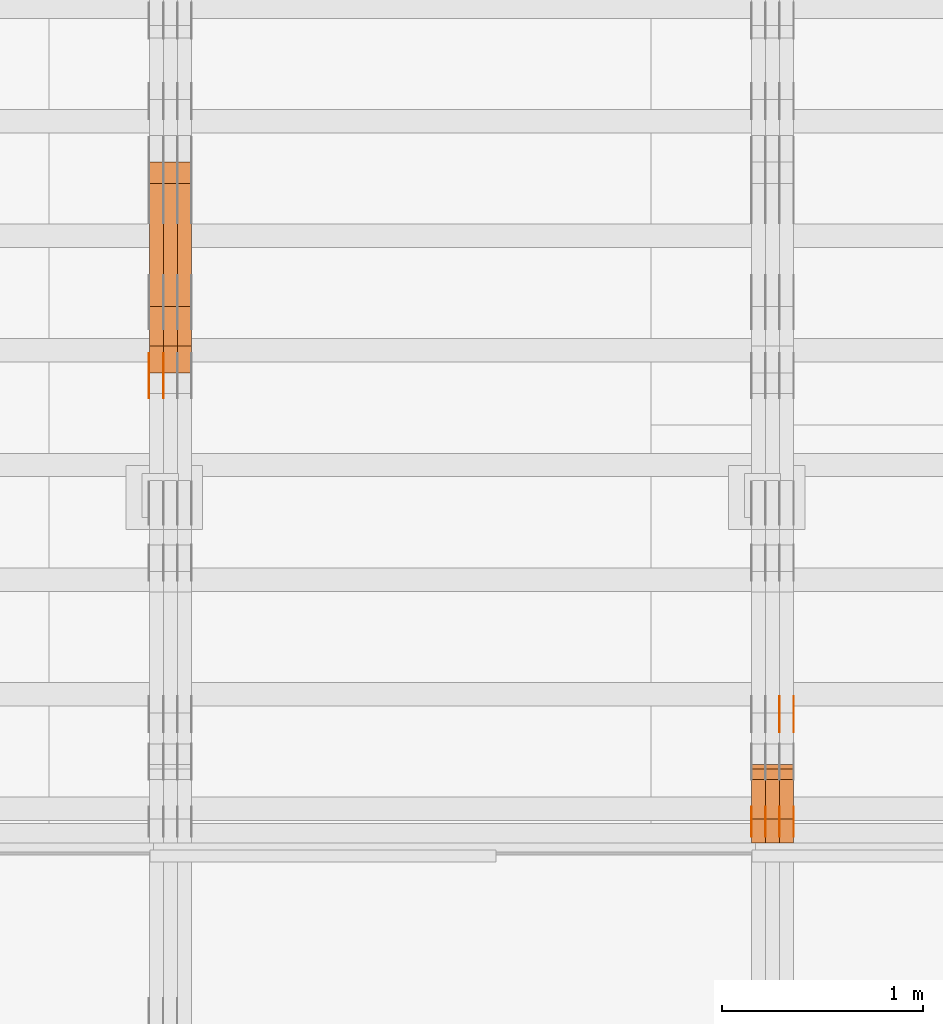
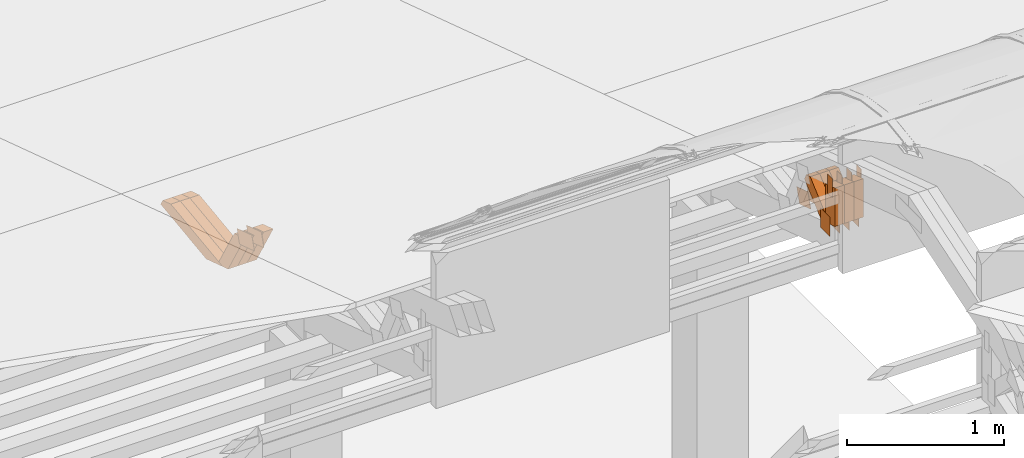
# One storey, part 302 of 385: 30 proxies.
"""IFC2X3 building model written with IfcOpenShell, lengths in millimetres."""

from ifc_helpers import new_model, entity, si_unit, converted_unit, derived_unit, direction, frame, origin, origin_2d_with_axis, place, context, subcontext, project, spatial, polyline, rectangle, outline, extrude, source, transform, mapped, material, type_object, type_shapes, element, save


model = new_model("IFC2X3")

# Units and contexts
model_context = context("Model", 3, precision=0.01, world=origin(), true_north=direction((6.12303176911189e-17, 1.0)))
body_context = subcontext(model_context, "Body", "Model", "MODEL_VIEW")
ifc_project = project(units=[si_unit("LENGTHUNIT", "METRE", prefix="MILLI"), si_unit("AREAUNIT", "SQUARE_METRE"), si_unit("VOLUMEUNIT", "CUBIC_METRE"), converted_unit("PLANEANGLEUNIT", "DEGREE", entity("IfcRatioMeasure", 0.0174532925199433), si_unit("PLANEANGLEUNIT", "RADIAN"), dimensions=[0, 0, 0, 0, 0, 0, 0]), si_unit("MASSUNIT", "GRAM", prefix="KILO"), derived_unit("MASSDENSITYUNIT", [(si_unit("MASSUNIT", "GRAM", prefix="KILO"), 1), (si_unit("LENGTHUNIT", "METRE"), -3)]), si_unit("TIMEUNIT", "SECOND"), si_unit("FREQUENCYUNIT", "HERTZ"), si_unit("THERMODYNAMICTEMPERATUREUNIT", "DEGREE_CELSIUS"), derived_unit("THERMALTRANSMITTANCEUNIT", [(si_unit("MASSUNIT", "GRAM", prefix="KILO"), 1), (si_unit("THERMODYNAMICTEMPERATUREUNIT", "KELVIN"), -1), (si_unit("TIMEUNIT", "SECOND"), -3)]), derived_unit("VOLUMETRICFLOWRATEUNIT", [(si_unit("LENGTHUNIT", "METRE"), 3), (si_unit("TIMEUNIT", "SECOND"), -1)]), si_unit("ELECTRICCURRENTUNIT", "AMPERE"), si_unit("ELECTRICVOLTAGEUNIT", "VOLT"), si_unit("POWERUNIT", "WATT"), si_unit("FORCEUNIT", "NEWTON", prefix="KILO"), si_unit("ILLUMINANCEUNIT", "LUX"), si_unit("LUMINOUSFLUXUNIT", "LUMEN"), si_unit("LUMINOUSINTENSITYUNIT", "CANDELA"), derived_unit("USERDEFINED", [(si_unit("MASSUNIT", "GRAM", prefix="KILO"), -1), (si_unit("LENGTHUNIT", "METRE"), -2), (si_unit("TIMEUNIT", "SECOND"), 3), (si_unit("LUMINOUSFLUXUNIT", "LUMEN"), 1)]), derived_unit("LINEARVELOCITYUNIT", [(si_unit("LENGTHUNIT", "METRE"), 1), (si_unit("TIMEUNIT", "SECOND"), -1)]), si_unit("PRESSUREUNIT", "PASCAL"), derived_unit("USERDEFINED", [(si_unit("LENGTHUNIT", "METRE"), -2), (si_unit("MASSUNIT", "GRAM", prefix="KILO"), 1), (si_unit("TIMEUNIT", "SECOND"), -2)])], contexts=[model_context])

# Site, building, storey
site_placement = place(None, origin())
site = spatial("IfcSite", under=ifc_project, at=site_placement, CompositionType="ELEMENT")
building_placement = place(site_placement, origin())
building = spatial("IfcBuilding", under=site, at=building_placement, CompositionType="ELEMENT")
storey_placement = place(building_placement, origin())
storey = spatial("IfcBuildingStorey", under=building, at=storey_placement, Name="Default", CompositionType="ELEMENT", Elevation=0.0)

# Proxies
ifc_material_1 = material(Name="IfcSurfaceStyle #549698")
building_element_proxy_type_1 = type_object("IfcBuildingElementProxyType", PredefinedType="NOTDEFINED", material=ifc_material_1)
shared_shape_1 = source(origin(), body_context, "Body", "SweptSolid", [
    extrude(rectangle(XDim=150.0, YDim=120.0, at=origin_2d_with_axis()), frame((75.0, 60.0, 0.0), z_axis=(0.0, 0.0, 1.0), x_axis=(-1.0, 0.0, 0.0)), (0.0, 0.0, 1.0), 1.3),
])
type_shapes(building_element_proxy_type_1, [shared_shape_1])
proxy_1_placement = place(building_placement, frame((45386.3, 15840.0, 3652.70166015625), z_axis=(-1.0, 0.0, 0.0), x_axis=(0.0, 0.0, -1.0)))
element("IfcBuildingElementProxy", 1, at=proxy_1_placement, inside=storey, type_object=building_element_proxy_type_1, material=ifc_material_1, context=body_context, shape_type="MappedRepresentation", body=[
    mapped(shared_shape_1, transform((0.0, 0.0, 0.0), scale=1.0)),
])
ifc_material_2 = material(Name="IfcSurfaceStyle #549641")
building_element_proxy_type_2 = type_object("IfcBuildingElementProxyType", PredefinedType="NOTDEFINED", material=ifc_material_2)
shared_shape_2 = source(origin(), body_context, "Body", "SweptSolid", [
    extrude(rectangle(XDim=150.0, YDim=120.0, at=origin_2d_with_axis()), frame((75.0, 60.0, 0.0), z_axis=(0.0, 0.0, 1.0), x_axis=(-1.0, 0.0, 0.0)), (0.0, 0.0, 1.0), 1.3),
])
type_shapes(building_element_proxy_type_2, [shared_shape_2])
proxy_2_placement = place(building_placement, frame((45315.0, 15840.0, 3652.70166015625), z_axis=(-1.0, 0.0, 0.0), x_axis=(0.0, 0.0, -1.0)))
element("IfcBuildingElementProxy", 2, at=proxy_2_placement, inside=storey, type_object=building_element_proxy_type_2, material=ifc_material_2, context=body_context, shape_type="MappedRepresentation", body=[
    mapped(shared_shape_2, transform((0.0, 0.0, 0.0), scale=1.0)),
])
ifc_material_3 = material(Name="IfcSurfaceStyle #549584")
building_element_proxy_type_3 = type_object("IfcBuildingElementProxyType", PredefinedType="NOTDEFINED", material=ifc_material_3)
shared_shape_3 = source(origin(), body_context, "Body", "SweptSolid", [
    extrude(rectangle(XDim=150.0, YDim=120.0, at=origin_2d_with_axis()), frame((75.0, 60.0, 0.0), z_axis=(0.0, 0.0, 1.0), x_axis=(-1.0, 0.0, 0.0)), (0.0, 0.0, 1.0), 1.3),
])
type_shapes(building_element_proxy_type_3, [shared_shape_3])
proxy_3_placement = place(building_placement, frame((45316.3, 15840.0, 3652.70166015625), z_axis=(-1.0, 0.0, 0.0), x_axis=(0.0, 0.0, -1.0)))
element("IfcBuildingElementProxy", 3, at=proxy_3_placement, inside=storey, type_object=building_element_proxy_type_3, material=ifc_material_3, context=body_context, shape_type="MappedRepresentation", body=[
    mapped(shared_shape_3, transform((0.0, 0.0, 0.0), scale=1.0)),
])
ifc_material_4 = material(Name="IfcSurfaceStyle #549527")
building_element_proxy_type_4 = type_object("IfcBuildingElementProxyType", PredefinedType="NOTDEFINED", material=ifc_material_4)
shared_shape_4 = source(origin(), body_context, "Body", "SweptSolid", [
    extrude(rectangle(XDim=150.0, YDim=120.0, at=origin_2d_with_axis()), frame((75.0, 60.0, 0.0), z_axis=(0.0, 0.0, 1.0), x_axis=(-1.0, 0.0, 0.0)), (0.0, 0.0, 1.0), 1.29999999999999),
])
type_shapes(building_element_proxy_type_4, [shared_shape_4])
proxy_4_placement = place(building_placement, frame((45245.0, 15840.0, 3652.70166015625), z_axis=(-1.0, 0.0, 0.0), x_axis=(0.0, 0.0, -1.0)))
element("IfcBuildingElementProxy", 4, at=proxy_4_placement, inside=storey, type_object=building_element_proxy_type_4, material=ifc_material_4, context=body_context, shape_type="MappedRepresentation", body=[
    mapped(shared_shape_4, transform((0.0, 0.0, 0.0), scale=1.0)),
])
ifc_material_5 = material(Name="IfcSurfaceStyle #549470")
building_element_proxy_type_5 = type_object("IfcBuildingElementProxyType", PredefinedType="NOTDEFINED", material=ifc_material_5)
shared_shape_5 = source(origin(), body_context, "Body", "SweptSolid", [
    extrude(rectangle(XDim=150.0, YDim=120.0, at=origin_2d_with_axis()), frame((75.0, 60.0, 0.0), z_axis=(0.0, 0.0, 1.0), x_axis=(-1.0, 0.0, 0.0)), (0.0, 0.0, 1.0), 1.29999999999999),
])
type_shapes(building_element_proxy_type_5, [shared_shape_5])
proxy_5_placement = place(building_placement, frame((45246.3, 15840.0, 3652.70166015625), z_axis=(-1.0, 0.0, 0.0), x_axis=(0.0, 0.0, -1.0)))
element("IfcBuildingElementProxy", 5, at=proxy_5_placement, inside=storey, type_object=building_element_proxy_type_5, material=ifc_material_5, context=body_context, shape_type="MappedRepresentation", body=[
    mapped(shared_shape_5, transform((0.0, 0.0, 0.0), scale=1.0)),
])
ifc_material_6 = material(Name="IfcSurfaceStyle #549413")
building_element_proxy_type_6 = type_object("IfcBuildingElementProxyType", PredefinedType="NOTDEFINED", material=ifc_material_6)
shared_shape_6 = source(origin(), body_context, "Body", "SweptSolid", [
    extrude(rectangle(XDim=150.0, YDim=120.0, at=origin_2d_with_axis()), frame((75.0, 60.0, 0.0), z_axis=(0.0, 0.0, 1.0), x_axis=(-1.0, 0.0, 0.0)), (0.0, 0.0, 1.0), 1.29999999999999),
])
type_shapes(building_element_proxy_type_6, [shared_shape_6])
proxy_6_placement = place(building_placement, frame((45175.0, 15840.0, 3652.70166015625), z_axis=(-1.0, 0.0, 0.0), x_axis=(0.0, 0.0, -1.0)))
element("IfcBuildingElementProxy", 6, at=proxy_6_placement, inside=storey, type_object=building_element_proxy_type_6, material=ifc_material_6, context=body_context, shape_type="MappedRepresentation", body=[
    mapped(shared_shape_6, transform((0.0, 0.0, 0.0), scale=1.0)),
])
ifc_material_7 = material(Name="IfcSurfaceStyle #549356")
building_element_proxy_type_7 = type_object("IfcBuildingElementProxyType", PredefinedType="NOTDEFINED", material=ifc_material_7)
shared_shape_7 = source(origin(), body_context, "Body", "SweptSolid", [
    extrude(outline(polyline([(-74.9998605591118, -59.9999264677601), (74.9998754286171, -59.9999264677601), (74.9998605591118, 59.9999264677602), (-74.9998754286171, 59.9999264677602), (-74.9998605591118, -59.9999264677601)])), frame((74.9998754286171, 60.0000503992849, 0.0), z_axis=(0.0, 0.0, 1.0), x_axis=(-1.0, 0.0, 0.0)), (0.0, 0.0, 1.0), 1.3),
])
type_shapes(building_element_proxy_type_7, [shared_shape_7])
proxy_7_placement = place(building_placement, frame((45386.3, 16352.8320303235, 3323.23212676408), z_axis=(-1.0, 0.0, 0.0), x_axis=(0.0, -0.951056516295124, 0.309016994375039)))
element("IfcBuildingElementProxy", 7, at=proxy_7_placement, inside=storey, type_object=building_element_proxy_type_7, material=ifc_material_7, context=body_context, shape_type="MappedRepresentation", body=[
    mapped(shared_shape_7, transform((0.0, 0.0, 0.0), scale=1.0)),
])
ifc_material_8 = material(Name="IfcSurfaceStyle #549299")
building_element_proxy_type_8 = type_object("IfcBuildingElementProxyType", PredefinedType="NOTDEFINED", material=ifc_material_8)
shared_shape_8 = source(origin(), body_context, "Body", "SweptSolid", [
    extrude(outline(polyline([(-74.9998605591118, -59.9999264677601), (74.9998754286171, -59.9999264677601), (74.9998605591118, 59.9999264677602), (-74.9998754286171, 59.9999264677602), (-74.9998605591118, -59.9999264677601)])), frame((74.9998754286171, 60.0000503992849, 0.0), z_axis=(0.0, 0.0, 1.0), x_axis=(-1.0, 0.0, 0.0)), (0.0, 0.0, 1.0), 1.3),
])
type_shapes(building_element_proxy_type_8, [shared_shape_8])
proxy_8_placement = place(building_placement, frame((45315.0, 16352.8320303235, 3323.23212676408), z_axis=(-1.0, 0.0, 0.0), x_axis=(0.0, -0.951056516295124, 0.309016994375039)))
element("IfcBuildingElementProxy", 8, at=proxy_8_placement, inside=storey, type_object=building_element_proxy_type_8, material=ifc_material_8, context=body_context, shape_type="MappedRepresentation", body=[
    mapped(shared_shape_8, transform((0.0, 0.0, 0.0), scale=1.0)),
])
ifc_material_9 = material(Name="IfcSurfaceStyle #549242")
building_element_proxy_type_9 = type_object("IfcBuildingElementProxyType", PredefinedType="NOTDEFINED", material=ifc_material_9)
shared_shape_9 = source(origin(), body_context, "Body", "SweptSolid", [
    extrude(outline(polyline([(-74.9998605591118, -59.9999264677601), (74.9998754286171, -59.9999264677601), (74.9998605591118, 59.9999264677602), (-74.9998754286171, 59.9999264677602), (-74.9998605591118, -59.9999264677601)])), frame((74.9998754286171, 60.0000503992849, 0.0), z_axis=(0.0, 0.0, 1.0), x_axis=(-1.0, 0.0, 0.0)), (0.0, 0.0, 1.0), 1.3),
])
type_shapes(building_element_proxy_type_9, [shared_shape_9])
proxy_9_placement = place(building_placement, frame((45316.3, 16352.8320303235, 3323.23212676408), z_axis=(-1.0, 0.0, 0.0), x_axis=(0.0, -0.951056516295124, 0.309016994375039)))
element("IfcBuildingElementProxy", 9, at=proxy_9_placement, inside=storey, type_object=building_element_proxy_type_9, material=ifc_material_9, context=body_context, shape_type="MappedRepresentation", body=[
    mapped(shared_shape_9, transform((0.0, 0.0, 0.0), scale=1.0)),
])
ifc_material_10 = material(Name="IfcSurfaceStyle #544226")
building_element_proxy_type_10 = type_object("IfcBuildingElementProxyType", PredefinedType="NOTDEFINED", material=ifc_material_10)
shared_shape_10 = source(origin(), body_context, "Body", "SweptSolid", [
    extrude(rectangle(XDim=150.0, YDim=60.0, at=origin_2d_with_axis()), frame((75.0000705696311, 30.0, 0.0), z_axis=(0.0, 0.0, 1.0), x_axis=(-1.0, 0.0, 0.0)), (0.0, 0.0, 1.0), 1.3),
])
type_shapes(building_element_proxy_type_10, [shared_shape_10])
proxy_10_placement = place(building_placement, frame((45386.3, 15750.0, 3972.59919166338), z_axis=(-1.0, 0.0, 0.0), x_axis=(0.0, 0.0, -1.0)))
element("IfcBuildingElementProxy", 10, at=proxy_10_placement, inside=storey, type_object=building_element_proxy_type_10, material=ifc_material_10, context=body_context, shape_type="MappedRepresentation", body=[
    mapped(shared_shape_10, transform((0.0, 0.0, 0.0), scale=1.0)),
])
ifc_material_11 = material(Name="IfcSurfaceStyle #544169")
building_element_proxy_type_11 = type_object("IfcBuildingElementProxyType", PredefinedType="NOTDEFINED", material=ifc_material_11)
shared_shape_11 = source(origin(), body_context, "Body", "SweptSolid", [
    extrude(rectangle(XDim=150.0, YDim=60.0, at=origin_2d_with_axis()), frame((75.0000705696311, 30.0, 0.0), z_axis=(0.0, 0.0, 1.0), x_axis=(-1.0, 0.0, 0.0)), (0.0, 0.0, 1.0), 1.3),
])
type_shapes(building_element_proxy_type_11, [shared_shape_11])
proxy_11_placement = place(building_placement, frame((45315.0, 15750.0, 3972.59919166338), z_axis=(-1.0, 0.0, 0.0), x_axis=(0.0, 0.0, -1.0)))
element("IfcBuildingElementProxy", 11, at=proxy_11_placement, inside=storey, type_object=building_element_proxy_type_11, material=ifc_material_11, context=body_context, shape_type="MappedRepresentation", body=[
    mapped(shared_shape_11, transform((0.0, 0.0, 0.0), scale=1.0)),
])
ifc_material_12 = material(Name="IfcSurfaceStyle #544112")
building_element_proxy_type_12 = type_object("IfcBuildingElementProxyType", PredefinedType="NOTDEFINED", material=ifc_material_12)
shared_shape_12 = source(origin(), body_context, "Body", "SweptSolid", [
    extrude(rectangle(XDim=150.0, YDim=60.0, at=origin_2d_with_axis()), frame((75.0000705696311, 30.0, 0.0), z_axis=(0.0, 0.0, 1.0), x_axis=(-1.0, 0.0, 0.0)), (0.0, 0.0, 1.0), 1.3),
])
type_shapes(building_element_proxy_type_12, [shared_shape_12])
proxy_12_placement = place(building_placement, frame((45316.3, 15750.0, 3972.59919166338), z_axis=(-1.0, 0.0, 0.0), x_axis=(0.0, 0.0, -1.0)))
element("IfcBuildingElementProxy", 12, at=proxy_12_placement, inside=storey, type_object=building_element_proxy_type_12, material=ifc_material_12, context=body_context, shape_type="MappedRepresentation", body=[
    mapped(shared_shape_12, transform((0.0, 0.0, 0.0), scale=1.0)),
])
ifc_material_13 = material(Name="IfcSurfaceStyle #544055")
building_element_proxy_type_13 = type_object("IfcBuildingElementProxyType", PredefinedType="NOTDEFINED", material=ifc_material_13)
shared_shape_13 = source(origin(), body_context, "Body", "SweptSolid", [
    extrude(rectangle(XDim=150.0, YDim=60.0, at=origin_2d_with_axis()), frame((75.0000705696311, 30.0, 0.0), z_axis=(0.0, 0.0, 1.0), x_axis=(-1.0, 0.0, 0.0)), (0.0, 0.0, 1.0), 1.29999999999999),
])
type_shapes(building_element_proxy_type_13, [shared_shape_13])
proxy_13_placement = place(building_placement, frame((45245.0, 15750.0, 3972.59919166338), z_axis=(-1.0, 0.0, 0.0), x_axis=(0.0, 0.0, -1.0)))
element("IfcBuildingElementProxy", 13, at=proxy_13_placement, inside=storey, type_object=building_element_proxy_type_13, material=ifc_material_13, context=body_context, shape_type="MappedRepresentation", body=[
    mapped(shared_shape_13, transform((0.0, 0.0, 0.0), scale=1.0)),
])
ifc_material_14 = material(Name="IfcSurfaceStyle #543998")
building_element_proxy_type_14 = type_object("IfcBuildingElementProxyType", PredefinedType="NOTDEFINED", material=ifc_material_14)
shared_shape_14 = source(origin(), body_context, "Body", "SweptSolid", [
    extrude(rectangle(XDim=150.0, YDim=60.0, at=origin_2d_with_axis()), frame((75.0000705696311, 30.0, 0.0), z_axis=(0.0, 0.0, 1.0), x_axis=(-1.0, 0.0, 0.0)), (0.0, 0.0, 1.0), 1.29999999999999),
])
type_shapes(building_element_proxy_type_14, [shared_shape_14])
proxy_14_placement = place(building_placement, frame((45246.3, 15750.0, 3972.59919166338), z_axis=(-1.0, 0.0, 0.0), x_axis=(0.0, 0.0, -1.0)))
element("IfcBuildingElementProxy", 14, at=proxy_14_placement, inside=storey, type_object=building_element_proxy_type_14, material=ifc_material_14, context=body_context, shape_type="MappedRepresentation", body=[
    mapped(shared_shape_14, transform((0.0, 0.0, 0.0), scale=1.0)),
])
ifc_material_15 = material(Name="IfcSurfaceStyle #543941")
building_element_proxy_type_15 = type_object("IfcBuildingElementProxyType", PredefinedType="NOTDEFINED", material=ifc_material_15)
shared_shape_15 = source(origin(), body_context, "Body", "SweptSolid", [
    extrude(rectangle(XDim=150.0, YDim=60.0, at=origin_2d_with_axis()), frame((75.0000705696311, 30.0, 0.0), z_axis=(0.0, 0.0, 1.0), x_axis=(-1.0, 0.0, 0.0)), (0.0, 0.0, 1.0), 1.29999999999999),
])
type_shapes(building_element_proxy_type_15, [shared_shape_15])
proxy_15_placement = place(building_placement, frame((45175.0, 15750.0, 3972.59919166338), z_axis=(-1.0, 0.0, 0.0), x_axis=(0.0, 0.0, -1.0)))
element("IfcBuildingElementProxy", 15, at=proxy_15_placement, inside=storey, type_object=building_element_proxy_type_15, material=ifc_material_15, context=body_context, shape_type="MappedRepresentation", body=[
    mapped(shared_shape_15, transform((0.0, 0.0, 0.0), scale=1.0)),
])
ifc_material_16 = material(Name="IfcSurfaceStyle #534857")
building_element_proxy_type_16 = type_object("IfcBuildingElementProxyType", Name="T1-W50 534855", PredefinedType="NOTDEFINED", material=ifc_material_16)
shared_shape_16 = source(origin(), body_context, "Body", "SweptSolid", [
    extrude(outline(polyline([(-128.56619634284, -47.4999385885712), (133.151257249084, -47.4999385885712), (161.172800006526, -0.000129729183733609), (147.291467726413, 47.500068317755), (-142.513973767368, 47.500068317755), (-170.535354871815, -0.000129729183754689), (-128.56619634284, -47.4999385885712)])), frame((161.17310141218, 47.5001898716564, 0.0), z_axis=(0.0, 0.0, 1.0), x_axis=(-1.0, 0.0, 0.0)), (0.0, 0.0, 1.0), 70.0),
])
type_shapes(building_element_proxy_type_16, [shared_shape_16])
proxy_16_placement = place(building_placement, frame((45385.0, 16060.0297689714, 3761.73994820667), z_axis=(-1.0, 0.0, 0.0), x_axis=(0.0, -0.749388407538668, -0.662130662820156)))
element("IfcBuildingElementProxy", 16, at=proxy_16_placement, inside=storey, type_object=building_element_proxy_type_16, material=ifc_material_16, Name="T1-W50", context=body_context, shape_type="MappedRepresentation", body=[
    mapped(shared_shape_16, transform((0.0, 0.0, 0.0), scale=1.0)),
])
ifc_material_17 = material(Name="IfcSurfaceStyle #534782")
building_element_proxy_type_17 = type_object("IfcBuildingElementProxyType", Name="T1-W50 534780", PredefinedType="NOTDEFINED", material=ifc_material_17)
shared_shape_17 = source(origin(), body_context, "Body", "SweptSolid", [
    extrude(outline(polyline([(-128.56619634284, -47.4999385885712), (133.151257249084, -47.4999385885712), (161.172800006526, -0.000129729183733609), (147.291467726413, 47.500068317755), (-142.513973767368, 47.500068317755), (-170.535354871815, -0.000129729183754689), (-128.56619634284, -47.4999385885712)])), frame((161.17310141218, 47.5001898716564, 0.0), z_axis=(0.0, 0.0, 1.0), x_axis=(-1.0, 0.0, 0.0)), (0.0, 0.0, 1.0), 70.0),
])
type_shapes(building_element_proxy_type_17, [shared_shape_17])
proxy_17_placement = place(building_placement, frame((45315.0, 16060.0297689714, 3761.73994820667), z_axis=(-1.0, 0.0, 0.0), x_axis=(0.0, -0.749388407538668, -0.662130662820156)))
element("IfcBuildingElementProxy", 17, at=proxy_17_placement, inside=storey, type_object=building_element_proxy_type_17, material=ifc_material_17, Name="T1-W50", context=body_context, shape_type="MappedRepresentation", body=[
    mapped(shared_shape_17, transform((0.0, 0.0, 0.0), scale=1.0)),
])
ifc_material_18 = material(Name="IfcSurfaceStyle #534707")
building_element_proxy_type_18 = type_object("IfcBuildingElementProxyType", Name="T1-W50 534705", PredefinedType="NOTDEFINED", material=ifc_material_18)
shared_shape_18 = source(origin(), body_context, "Body", "SweptSolid", [
    extrude(outline(polyline([(-128.56619634284, -47.4999385885712), (133.151257249084, -47.4999385885712), (161.172800006526, -0.000129729183733609), (147.291467726413, 47.500068317755), (-142.513973767368, 47.500068317755), (-170.535354871815, -0.000129729183754689), (-128.56619634284, -47.4999385885712)])), frame((161.17310141218, 47.5001898716564, 0.0), z_axis=(0.0, 0.0, 1.0), x_axis=(-1.0, 0.0, 0.0)), (0.0, 0.0, 1.0), 70.0),
])
type_shapes(building_element_proxy_type_18, [shared_shape_18])
proxy_18_placement = place(building_placement, frame((45245.0, 16060.0297689714, 3761.73994820667), z_axis=(-1.0, 0.0, 0.0), x_axis=(0.0, -0.749388407538668, -0.662130662820156)))
element("IfcBuildingElementProxy", 18, at=proxy_18_placement, inside=storey, type_object=building_element_proxy_type_18, material=ifc_material_18, Name="T1-W50", context=body_context, shape_type="MappedRepresentation", body=[
    mapped(shared_shape_18, transform((0.0, 0.0, 0.0), scale=1.0)),
])
ifc_material_19 = material(Name="IfcSurfaceStyle #534461")
building_element_proxy_type_19 = type_object("IfcBuildingElementProxyType", Name="T1-W2 534459", PredefinedType="NOTDEFINED", material=ifc_material_19)
shared_shape_19 = source(origin(), body_context, "Body", "SweptSolid", [
    extrude(outline(polyline([(-130.705993652344, -60.0), (169.696350097656, -60.0), (130.706115722656, 60.0), (-169.696472167969, 60.0), (-130.705993652344, -60.0)])), frame((169.696429629256, 60.0, 0.0), z_axis=(0.0, 0.0, 1.0), x_axis=(-1.0, 0.0, 0.0)), (0.0, 0.0, 1.0), 70.0),
])
type_shapes(building_element_proxy_type_19, [shared_shape_19])
proxy_19_placement = place(building_placement, frame((45385.0, 15660.0, 3577.70158062465), z_axis=(-1.0, 0.0, 0.0), x_axis=(0.0, 0.0, 1.0)))
element("IfcBuildingElementProxy", 19, at=proxy_19_placement, inside=storey, type_object=building_element_proxy_type_19, material=ifc_material_19, Name="T1-W2", context=body_context, shape_type="MappedRepresentation", body=[
    mapped(shared_shape_19, transform((0.0, 0.0, 0.0), scale=1.0)),
])
ifc_material_20 = material(Name="IfcSurfaceStyle #534404")
building_element_proxy_type_20 = type_object("IfcBuildingElementProxyType", Name="T1-W2 534402", PredefinedType="NOTDEFINED", material=ifc_material_20)
shared_shape_20 = source(origin(), body_context, "Body", "SweptSolid", [
    extrude(outline(polyline([(-130.705993652344, -60.0), (169.696350097656, -60.0), (130.706115722656, 60.0), (-169.696472167969, 60.0), (-130.705993652344, -60.0)])), frame((169.696429629256, 60.0, 0.0), z_axis=(0.0, 0.0, 1.0), x_axis=(-1.0, 0.0, 0.0)), (0.0, 0.0, 1.0), 70.0),
])
type_shapes(building_element_proxy_type_20, [shared_shape_20])
proxy_20_placement = place(building_placement, frame((45315.0, 15660.0, 3577.70158062465), z_axis=(-1.0, 0.0, 0.0), x_axis=(0.0, 0.0, 1.0)))
element("IfcBuildingElementProxy", 20, at=proxy_20_placement, inside=storey, type_object=building_element_proxy_type_20, material=ifc_material_20, Name="T1-W2", context=body_context, shape_type="MappedRepresentation", body=[
    mapped(shared_shape_20, transform((0.0, 0.0, 0.0), scale=1.0)),
])
ifc_material_21 = material(Name="IfcSurfaceStyle #534347")
building_element_proxy_type_21 = type_object("IfcBuildingElementProxyType", Name="T1-W2 534345", PredefinedType="NOTDEFINED", material=ifc_material_21)
shared_shape_21 = source(origin(), body_context, "Body", "SweptSolid", [
    extrude(outline(polyline([(-130.705993652344, -60.0), (169.696350097656, -60.0), (130.706115722656, 60.0), (-169.696472167969, 60.0), (-130.705993652344, -60.0)])), frame((169.696429629256, 60.0, 0.0), z_axis=(0.0, 0.0, 1.0), x_axis=(-1.0, 0.0, 0.0)), (0.0, 0.0, 1.0), 70.0),
])
type_shapes(building_element_proxy_type_21, [shared_shape_21])
proxy_21_placement = place(building_placement, frame((45245.0, 15660.0, 3577.70158062465), z_axis=(-1.0, 0.0, 0.0), x_axis=(0.0, 0.0, 1.0)))
element("IfcBuildingElementProxy", 21, at=proxy_21_placement, inside=storey, type_object=building_element_proxy_type_21, material=ifc_material_21, Name="T1-W2", context=body_context, shape_type="MappedRepresentation", body=[
    mapped(shared_shape_21, transform((0.0, 0.0, 0.0), scale=1.0)),
])
ifc_material_22 = material(Name="IfcSurfaceStyle #508255")
building_element_proxy_type_22 = type_object("IfcBuildingElementProxyType", PredefinedType="NOTDEFINED", material=ifc_material_22)
shared_shape_22 = source(origin(), body_context, "Body", "SweptSolid", [
    extrude(outline(polyline([(-99.9999427841299, -54.0000599375792), (99.9996549037756, -54.0000599375792), (100.000407167194, 54.0000599375792), (-100.00011928684, 54.0000599375792), (-99.9999427841299, -54.0000599375792)])), frame((100.000407167194, 54.0000599375792, 0.0), z_axis=(0.0, 0.0, 1.0), x_axis=(-1.0, 0.0, 0.0)), (0.0, 0.0, 1.0), 1.29999999999998),
])
type_shapes(building_element_proxy_type_22, [shared_shape_22])
proxy_22_placement = place(building_placement, frame((42245.0, 18065.0682492591, 3072.55239547302), z_axis=(-1.0, 0.0, 0.0), x_axis=(0.0, -0.951056516295154, 0.309016994374948)))
element("IfcBuildingElementProxy", 22, at=proxy_22_placement, inside=storey, type_object=building_element_proxy_type_22, material=ifc_material_22, context=body_context, shape_type="MappedRepresentation", body=[
    mapped(shared_shape_22, transform((0.0, 0.0, 0.0), scale=1.0)),
])
ifc_material_23 = material(Name="IfcSurfaceStyle #508198")
building_element_proxy_type_23 = type_object("IfcBuildingElementProxyType", PredefinedType="NOTDEFINED", material=ifc_material_23)
shared_shape_23 = source(origin(), body_context, "Body", "SweptSolid", [
    extrude(outline(polyline([(-99.9999427841299, -54.0000599375792), (99.9996549037756, -54.0000599375792), (100.000407167194, 54.0000599375792), (-100.00011928684, 54.0000599375792), (-99.9999427841299, -54.0000599375792)])), frame((100.000407167194, 54.0000599375792, 0.0), z_axis=(0.0, 0.0, 1.0), x_axis=(-1.0, 0.0, 0.0)), (0.0, 0.0, 1.0), 1.29999999999998),
])
type_shapes(building_element_proxy_type_23, [shared_shape_23])
proxy_23_placement = place(building_placement, frame((42246.3, 18065.0682492591, 3072.55239547302), z_axis=(-1.0, 0.0, 0.0), x_axis=(0.0, -0.951056516295154, 0.309016994374948)))
element("IfcBuildingElementProxy", 23, at=proxy_23_placement, inside=storey, type_object=building_element_proxy_type_23, material=ifc_material_23, context=body_context, shape_type="MappedRepresentation", body=[
    mapped(shared_shape_23, transform((0.0, 0.0, 0.0), scale=1.0)),
])
ifc_material_24 = material(Name="IfcSurfaceStyle #508141")
building_element_proxy_type_24 = type_object("IfcBuildingElementProxyType", PredefinedType="NOTDEFINED", material=ifc_material_24)
shared_shape_24 = source(origin(), body_context, "Body", "SweptSolid", [
    extrude(outline(polyline([(-99.9999427841299, -54.0000599375792), (99.9996549037756, -54.0000599375792), (100.000407167194, 54.0000599375792), (-100.00011928684, 54.0000599375792), (-99.9999427841299, -54.0000599375792)])), frame((100.000407167194, 54.0000599375792, 0.0), z_axis=(0.0, 0.0, 1.0), x_axis=(-1.0, 0.0, 0.0)), (0.0, 0.0, 1.0), 1.29999999999999),
])
type_shapes(building_element_proxy_type_24, [shared_shape_24])
proxy_24_placement = place(building_placement, frame((42175.0, 18065.0682492591, 3072.55239547302), z_axis=(-1.0, 0.0, 0.0), x_axis=(0.0, -0.951056516295154, 0.309016994374948)))
element("IfcBuildingElementProxy", 24, at=proxy_24_placement, inside=storey, type_object=building_element_proxy_type_24, material=ifc_material_24, context=body_context, shape_type="MappedRepresentation", body=[
    mapped(shared_shape_24, transform((0.0, 0.0, 0.0), scale=1.0)),
])
ifc_material_25 = material(Name="IfcSurfaceStyle #498274")
building_element_proxy_type_25 = type_object("IfcBuildingElementProxyType", Name="T1-W35 498272", PredefinedType="NOTDEFINED", material=ifc_material_25)
shared_shape_25 = source(origin(), body_context, "Body", "SweptSolid", [
    extrude(outline(polyline([(-196.877231354918, -47.499850828051), (197.289756738813, -47.499850828051), (177.380838136073, -0.000131002767018074), (124.615181369032, 47.4999163294346), (-302.408544889, 47.4999163294346), (-196.877231354918, -47.499850828051)])), frame((197.289756738813, 47.5002438363521, 0.0), z_axis=(0.0, 0.0, 1.0), x_axis=(-1.0, 0.0, 0.0)), (0.0, 0.0, 1.0), 70.0),
])
type_shapes(building_element_proxy_type_25, [shared_shape_25])
proxy_25_placement = place(building_placement, frame((42385.0, 18249.5528960018, 2724.16980022534), z_axis=(-1.0, 0.0, 0.0), x_axis=(0.0, -0.5, 0.866025403784439)))
element("IfcBuildingElementProxy", 25, at=proxy_25_placement, inside=storey, type_object=building_element_proxy_type_25, material=ifc_material_25, Name="T1-W35", context=body_context, shape_type="MappedRepresentation", body=[
    mapped(shared_shape_25, transform((0.0, 0.0, 0.0), scale=1.0)),
])
ifc_material_26 = material(Name="IfcSurfaceStyle #498208")
building_element_proxy_type_26 = type_object("IfcBuildingElementProxyType", Name="T1-W35 498206", PredefinedType="NOTDEFINED", material=ifc_material_26)
shared_shape_26 = source(origin(), body_context, "Body", "SweptSolid", [
    extrude(outline(polyline([(-196.877231354918, -47.499850828051), (197.289756738813, -47.499850828051), (177.380838136073, -0.000131002767018074), (124.615181369032, 47.4999163294346), (-302.408544889, 47.4999163294346), (-196.877231354918, -47.499850828051)])), frame((197.289756738813, 47.5002438363521, 0.0), z_axis=(0.0, 0.0, 1.0), x_axis=(-1.0, 0.0, 0.0)), (0.0, 0.0, 1.0), 70.0),
])
type_shapes(building_element_proxy_type_26, [shared_shape_26])
proxy_26_placement = place(building_placement, frame((42315.0, 18249.5528960018, 2724.16980022534), z_axis=(-1.0, 0.0, 0.0), x_axis=(0.0, -0.5, 0.866025403784439)))
element("IfcBuildingElementProxy", 26, at=proxy_26_placement, inside=storey, type_object=building_element_proxy_type_26, material=ifc_material_26, Name="T1-W35", context=body_context, shape_type="MappedRepresentation", body=[
    mapped(shared_shape_26, transform((0.0, 0.0, 0.0), scale=1.0)),
])
ifc_material_27 = material(Name="IfcSurfaceStyle #498142")
building_element_proxy_type_27 = type_object("IfcBuildingElementProxyType", Name="T1-W35 498140", PredefinedType="NOTDEFINED", material=ifc_material_27)
shared_shape_27 = source(origin(), body_context, "Body", "SweptSolid", [
    extrude(outline(polyline([(-196.877231354918, -47.499850828051), (197.289756738813, -47.499850828051), (177.380838136073, -0.000131002767018074), (124.615181369032, 47.4999163294346), (-302.408544889, 47.4999163294346), (-196.877231354918, -47.499850828051)])), frame((197.289756738813, 47.5002438363521, 0.0), z_axis=(0.0, 0.0, 1.0), x_axis=(-1.0, 0.0, 0.0)), (0.0, 0.0, 1.0), 70.0),
])
type_shapes(building_element_proxy_type_27, [shared_shape_27])
proxy_27_placement = place(building_placement, frame((42245.0, 18249.5528960018, 2724.16980022534), z_axis=(-1.0, 0.0, 0.0), x_axis=(0.0, -0.5, 0.866025403784439)))
element("IfcBuildingElementProxy", 27, at=proxy_27_placement, inside=storey, type_object=building_element_proxy_type_27, material=ifc_material_27, Name="T1-W35", context=body_context, shape_type="MappedRepresentation", body=[
    mapped(shared_shape_27, transform((0.0, 0.0, 0.0), scale=1.0)),
])
ifc_material_28 = material(Name="IfcSurfaceStyle #497878")
building_element_proxy_type_28 = type_object("IfcBuildingElementProxyType", Name="T1-W6 497876", PredefinedType="NOTDEFINED", material=ifc_material_28)
shared_shape_28 = source(origin(), body_context, "Body", "SweptSolid", [
    extrude(outline(polyline([(-485.945461934772, -47.500204767976), (183.41906495488, -47.500204767976), (284.061400026172, 0.000179660053988773), (303.127757064591, 47.500114937949), (-284.66276011087, 47.500114937949), (-485.945461934772, -47.500204767976)])), frame((303.127970456024, 47.5001450766485, 0.0), z_axis=(0.0, 0.0, 1.0), x_axis=(-1.0, 0.0, 0.0)), (0.0, 0.0, 1.0), 70.0),
])
type_shapes(building_element_proxy_type_28, [shared_shape_28])
proxy_28_placement = place(building_placement, frame((42385.0, 19075.4826373647, 2770.72729201433), z_axis=(-1.0, 0.0, 0.0), x_axis=(0.0, -0.991969529622927, -0.126477082112413)))
element("IfcBuildingElementProxy", 28, at=proxy_28_placement, inside=storey, type_object=building_element_proxy_type_28, material=ifc_material_28, Name="T1-W6", context=body_context, shape_type="MappedRepresentation", body=[
    mapped(shared_shape_28, transform((0.0, 0.0, 0.0), scale=1.0)),
])
ifc_material_29 = material(Name="IfcSurfaceStyle #497812")
building_element_proxy_type_29 = type_object("IfcBuildingElementProxyType", Name="T1-W6 497810", PredefinedType="NOTDEFINED", material=ifc_material_29)
shared_shape_29 = source(origin(), body_context, "Body", "SweptSolid", [
    extrude(outline(polyline([(-485.945461934772, -47.500204767976), (183.41906495488, -47.500204767976), (284.061400026172, 0.000179660053988773), (303.127757064591, 47.500114937949), (-284.66276011087, 47.500114937949), (-485.945461934772, -47.500204767976)])), frame((303.127970456024, 47.5001450766485, 0.0), z_axis=(0.0, 0.0, 1.0), x_axis=(-1.0, 0.0, 0.0)), (0.0, 0.0, 1.0), 70.0),
])
type_shapes(building_element_proxy_type_29, [shared_shape_29])
proxy_29_placement = place(building_placement, frame((42315.0, 19075.4826373647, 2770.72729201433), z_axis=(-1.0, 0.0, 0.0), x_axis=(0.0, -0.991969529622927, -0.126477082112413)))
element("IfcBuildingElementProxy", 29, at=proxy_29_placement, inside=storey, type_object=building_element_proxy_type_29, material=ifc_material_29, Name="T1-W6", context=body_context, shape_type="MappedRepresentation", body=[
    mapped(shared_shape_29, transform((0.0, 0.0, 0.0), scale=1.0)),
])
ifc_material_30 = material(Name="IfcSurfaceStyle #497746")
building_element_proxy_type_30 = type_object("IfcBuildingElementProxyType", Name="T1-W6 497744", PredefinedType="NOTDEFINED", material=ifc_material_30)
shared_shape_30 = source(origin(), body_context, "Body", "SweptSolid", [
    extrude(outline(polyline([(-485.945461934772, -47.500204767976), (183.41906495488, -47.500204767976), (284.061400026172, 0.000179660053988773), (303.127757064591, 47.500114937949), (-284.66276011087, 47.500114937949), (-485.945461934772, -47.500204767976)])), frame((303.127970456024, 47.5001450766485, 0.0), z_axis=(0.0, 0.0, 1.0), x_axis=(-1.0, 0.0, 0.0)), (0.0, 0.0, 1.0), 70.0),
])
type_shapes(building_element_proxy_type_30, [shared_shape_30])
proxy_30_placement = place(building_placement, frame((42245.0, 19075.4826373647, 2770.72729201433), z_axis=(-1.0, 0.0, 0.0), x_axis=(0.0, -0.991969529622927, -0.126477082112413)))
element("IfcBuildingElementProxy", 30, at=proxy_30_placement, inside=storey, type_object=building_element_proxy_type_30, material=ifc_material_30, Name="T1-W6", context=body_context, shape_type="MappedRepresentation", body=[
    mapped(shared_shape_30, transform((0.0, 0.0, 0.0), scale=1.0)),
])

save(model, "model.ifc")
